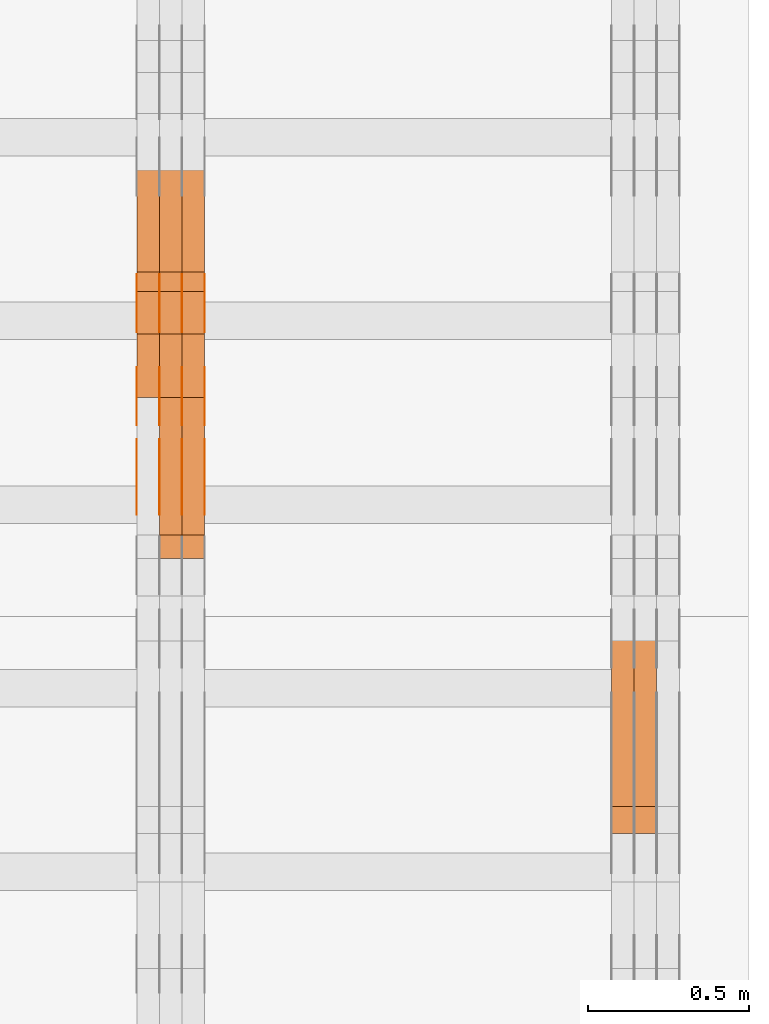
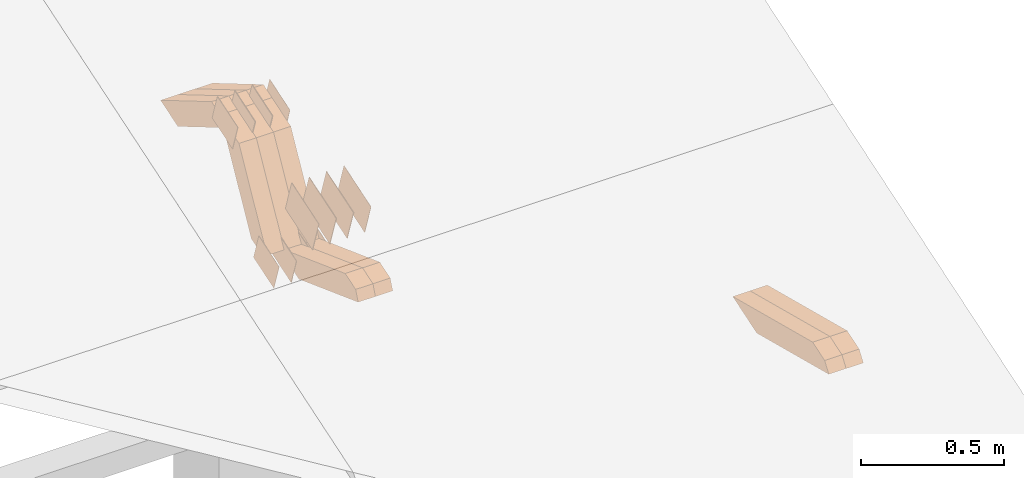
# One storey, part 316 of 385: 28 proxies.
"""IFC2X3 building model written with IfcOpenShell, lengths in millimetres."""

from ifc_helpers import new_model, entity, si_unit, converted_unit, derived_unit, direction, frame, origin, place, context, subcontext, project, spatial, polyline, outline, extrude, source, transform, mapped, material, type_object, type_shapes, element, save


model = new_model("IFC2X3")

# Units and contexts
model_context = context("Model", 3, precision=0.01, world=origin(), true_north=direction((6.12303176911189e-17, 1.0)))
body_context = subcontext(model_context, "Body", "Model", "MODEL_VIEW")
ifc_project = project(units=[si_unit("LENGTHUNIT", "METRE", prefix="MILLI"), si_unit("AREAUNIT", "SQUARE_METRE"), si_unit("VOLUMEUNIT", "CUBIC_METRE"), converted_unit("PLANEANGLEUNIT", "DEGREE", entity("IfcRatioMeasure", 0.0174532925199433), si_unit("PLANEANGLEUNIT", "RADIAN"), dimensions=[0, 0, 0, 0, 0, 0, 0]), si_unit("MASSUNIT", "GRAM", prefix="KILO"), derived_unit("MASSDENSITYUNIT", [(si_unit("MASSUNIT", "GRAM", prefix="KILO"), 1), (si_unit("LENGTHUNIT", "METRE"), -3)]), si_unit("TIMEUNIT", "SECOND"), si_unit("FREQUENCYUNIT", "HERTZ"), si_unit("THERMODYNAMICTEMPERATUREUNIT", "DEGREE_CELSIUS"), derived_unit("THERMALTRANSMITTANCEUNIT", [(si_unit("MASSUNIT", "GRAM", prefix="KILO"), 1), (si_unit("THERMODYNAMICTEMPERATUREUNIT", "KELVIN"), -1), (si_unit("TIMEUNIT", "SECOND"), -3)]), derived_unit("VOLUMETRICFLOWRATEUNIT", [(si_unit("LENGTHUNIT", "METRE"), 3), (si_unit("TIMEUNIT", "SECOND"), -1)]), si_unit("ELECTRICCURRENTUNIT", "AMPERE"), si_unit("ELECTRICVOLTAGEUNIT", "VOLT"), si_unit("POWERUNIT", "WATT"), si_unit("FORCEUNIT", "NEWTON", prefix="KILO"), si_unit("ILLUMINANCEUNIT", "LUX"), si_unit("LUMINOUSFLUXUNIT", "LUMEN"), si_unit("LUMINOUSINTENSITYUNIT", "CANDELA"), derived_unit("USERDEFINED", [(si_unit("MASSUNIT", "GRAM", prefix="KILO"), -1), (si_unit("LENGTHUNIT", "METRE"), -2), (si_unit("TIMEUNIT", "SECOND"), 3), (si_unit("LUMINOUSFLUXUNIT", "LUMEN"), 1)]), derived_unit("LINEARVELOCITYUNIT", [(si_unit("LENGTHUNIT", "METRE"), 1), (si_unit("TIMEUNIT", "SECOND"), -1)]), si_unit("PRESSUREUNIT", "PASCAL"), derived_unit("USERDEFINED", [(si_unit("LENGTHUNIT", "METRE"), -2), (si_unit("MASSUNIT", "GRAM", prefix="KILO"), 1), (si_unit("TIMEUNIT", "SECOND"), -2)])], contexts=[model_context])

# Site, building, storey
site_placement = place(None, origin())
site = spatial("IfcSite", under=ifc_project, at=site_placement, CompositionType="ELEMENT")
building_placement = place(site_placement, origin())
building = spatial("IfcBuilding", under=site, at=building_placement, CompositionType="ELEMENT")
storey_placement = place(building_placement, origin())
storey = spatial("IfcBuildingStorey", under=building, at=storey_placement, Name="Default", CompositionType="ELEMENT", Elevation=0.0)

# Proxies
ifc_material_1 = material(Name="IfcSurfaceStyle #598534")
building_element_proxy_type_1 = type_object("IfcBuildingElementProxyType", Name="T2-W11 598532", PredefinedType="NOTDEFINED", material=ifc_material_1)
shared_shape_1 = source(origin(), body_context, "Body", "SweptSolid", [
    extrude(outline(polyline([(-261.366417792209, -47.5000378467523), (260.949520182121, -47.5000378467523), (242.928845159301, -7.41559889341215e-06), (168.237407166939, 47.5000415545517), (-410.749354716152, 47.5000415545517), (-261.366417792209, -47.5000378467523)])), frame((260.949520182121, 47.5000415545517, 0.0), z_axis=(0.0, 0.0, 1.0), x_axis=(-1.0, 0.0, 0.0)), (0.0, 0.0, 1.0), 70.0),
])
type_shapes(building_element_proxy_type_1, [shared_shape_1])
proxy_1_placement = place(building_placement, frame((49790.0, 8017.44318793234, 2097.03832883996), z_axis=(-1.0, 0.0, 0.0), x_axis=(0.0, 0.968347201599873, -0.249607085543851)))
element("IfcBuildingElementProxy", 1, at=proxy_1_placement, inside=storey, type_object=building_element_proxy_type_1, material=ifc_material_1, Name="T2-W11", context=body_context, shape_type="MappedRepresentation", body=[
    mapped(shared_shape_1, transform((0.0, 0.0, 0.0), scale=1.0)),
])
ifc_material_2 = material(Name="IfcSurfaceStyle #598468")
building_element_proxy_type_2 = type_object("IfcBuildingElementProxyType", Name="T2-W11 598466", PredefinedType="NOTDEFINED", material=ifc_material_2)
shared_shape_2 = source(origin(), body_context, "Body", "SweptSolid", [
    extrude(outline(polyline([(-261.366417792209, -47.5000378467523), (260.949520182121, -47.5000378467523), (242.928845159301, -7.41559889341215e-06), (168.237407166939, 47.5000415545517), (-410.749354716152, 47.5000415545517), (-261.366417792209, -47.5000378467523)])), frame((260.949520182121, 47.5000415545517, 0.0), z_axis=(0.0, 0.0, 1.0), x_axis=(-1.0, 0.0, 0.0)), (0.0, 0.0, 1.0), 70.0),
])
type_shapes(building_element_proxy_type_2, [shared_shape_2])
proxy_2_placement = place(building_placement, frame((49720.0, 8017.44318793234, 2097.03832883996), z_axis=(-1.0, 0.0, 0.0), x_axis=(0.0, 0.968347201599873, -0.249607085543851)))
element("IfcBuildingElementProxy", 2, at=proxy_2_placement, inside=storey, type_object=building_element_proxy_type_2, material=ifc_material_2, Name="T2-W11", context=body_context, shape_type="MappedRepresentation", body=[
    mapped(shared_shape_2, transform((0.0, 0.0, 0.0), scale=1.0)),
])
ifc_material_3 = material(Name="IfcSurfaceStyle #590286")
building_element_proxy_type_3 = type_object("IfcBuildingElementProxyType", PredefinedType="NOTDEFINED", material=ifc_material_3)
shared_shape_3 = source(origin(), body_context, "Body", "SweptSolid", [
    extrude(outline(polyline([(-99.999644645517, -72.0000317581407), (100.000028485991, -72.0000317581407), (99.999644645517, 72.0000317581407), (-100.000028485991, 72.0000317581407), (-99.999644645517, -72.0000317581407)])), frame((100.000028485991, 72.0000317581407, 0.0), z_axis=(0.0, 0.0, 1.0), x_axis=(-1.0, 0.0, 0.0)), (0.0, 0.0, 1.0), 1.3),
])
type_shapes(building_element_proxy_type_3, [shared_shape_3])
proxy_3_placement = place(building_placement, frame((48386.3, 9012.6304394324, 2546.30522609783), z_axis=(-1.0, 0.0, 0.0), x_axis=(0.0, 0.951056516295154, 0.309016994374948)))
element("IfcBuildingElementProxy", 3, at=proxy_3_placement, inside=storey, type_object=building_element_proxy_type_3, material=ifc_material_3, context=body_context, shape_type="MappedRepresentation", body=[
    mapped(shared_shape_3, transform((0.0, 0.0, 0.0), scale=1.0)),
])
ifc_material_4 = material(Name="IfcSurfaceStyle #590229")
building_element_proxy_type_4 = type_object("IfcBuildingElementProxyType", PredefinedType="NOTDEFINED", material=ifc_material_4)
shared_shape_4 = source(origin(), body_context, "Body", "SweptSolid", [
    extrude(outline(polyline([(-99.999644645517, -72.0000317581407), (100.000028485991, -72.0000317581407), (99.999644645517, 72.0000317581407), (-100.000028485991, 72.0000317581407), (-99.999644645517, -72.0000317581407)])), frame((100.000028485991, 72.0000317581407, 0.0), z_axis=(0.0, 0.0, 1.0), x_axis=(-1.0, 0.0, 0.0)), (0.0, 0.0, 1.0), 1.3),
])
type_shapes(building_element_proxy_type_4, [shared_shape_4])
proxy_4_placement = place(building_placement, frame((48315.0, 9012.6304394324, 2546.30522609783), z_axis=(-1.0, 0.0, 0.0), x_axis=(0.0, 0.951056516295154, 0.309016994374948)))
element("IfcBuildingElementProxy", 4, at=proxy_4_placement, inside=storey, type_object=building_element_proxy_type_4, material=ifc_material_4, context=body_context, shape_type="MappedRepresentation", body=[
    mapped(shared_shape_4, transform((0.0, 0.0, 0.0), scale=1.0)),
])
ifc_material_5 = material(Name="IfcSurfaceStyle #590172")
building_element_proxy_type_5 = type_object("IfcBuildingElementProxyType", PredefinedType="NOTDEFINED", material=ifc_material_5)
shared_shape_5 = source(origin(), body_context, "Body", "SweptSolid", [
    extrude(outline(polyline([(-99.999644645517, -72.0000317581407), (100.000028485991, -72.0000317581407), (99.999644645517, 72.0000317581407), (-100.000028485991, 72.0000317581407), (-99.999644645517, -72.0000317581407)])), frame((100.000028485991, 72.0000317581407, 0.0), z_axis=(0.0, 0.0, 1.0), x_axis=(-1.0, 0.0, 0.0)), (0.0, 0.0, 1.0), 1.3),
])
type_shapes(building_element_proxy_type_5, [shared_shape_5])
proxy_5_placement = place(building_placement, frame((48316.3, 9012.6304394324, 2546.30522609783), z_axis=(-1.0, 0.0, 0.0), x_axis=(0.0, 0.951056516295154, 0.309016994374948)))
element("IfcBuildingElementProxy", 5, at=proxy_5_placement, inside=storey, type_object=building_element_proxy_type_5, material=ifc_material_5, context=body_context, shape_type="MappedRepresentation", body=[
    mapped(shared_shape_5, transform((0.0, 0.0, 0.0), scale=1.0)),
])
ifc_material_6 = material(Name="IfcSurfaceStyle #590115")
building_element_proxy_type_6 = type_object("IfcBuildingElementProxyType", PredefinedType="NOTDEFINED", material=ifc_material_6)
shared_shape_6 = source(origin(), body_context, "Body", "SweptSolid", [
    extrude(outline(polyline([(-99.999644645517, -72.0000317581407), (100.000028485991, -72.0000317581407), (99.999644645517, 72.0000317581407), (-100.000028485991, 72.0000317581407), (-99.999644645517, -72.0000317581407)])), frame((100.000028485991, 72.0000317581407, 0.0), z_axis=(0.0, 0.0, 1.0), x_axis=(-1.0, 0.0, 0.0)), (0.0, 0.0, 1.0), 1.29999999999998),
])
type_shapes(building_element_proxy_type_6, [shared_shape_6])
proxy_6_placement = place(building_placement, frame((48245.0, 9012.6304394324, 2546.30522609783), z_axis=(-1.0, 0.0, 0.0), x_axis=(0.0, 0.951056516295154, 0.309016994374948)))
element("IfcBuildingElementProxy", 6, at=proxy_6_placement, inside=storey, type_object=building_element_proxy_type_6, material=ifc_material_6, context=body_context, shape_type="MappedRepresentation", body=[
    mapped(shared_shape_6, transform((0.0, 0.0, 0.0), scale=1.0)),
])
ifc_material_7 = material(Name="IfcSurfaceStyle #590058")
building_element_proxy_type_7 = type_object("IfcBuildingElementProxyType", PredefinedType="NOTDEFINED", material=ifc_material_7)
shared_shape_7 = source(origin(), body_context, "Body", "SweptSolid", [
    extrude(outline(polyline([(-99.999644645517, -72.0000317581407), (100.000028485991, -72.0000317581407), (99.999644645517, 72.0000317581407), (-100.000028485991, 72.0000317581407), (-99.999644645517, -72.0000317581407)])), frame((100.000028485991, 72.0000317581407, 0.0), z_axis=(0.0, 0.0, 1.0), x_axis=(-1.0, 0.0, 0.0)), (0.0, 0.0, 1.0), 1.29999999999998),
])
type_shapes(building_element_proxy_type_7, [shared_shape_7])
proxy_7_placement = place(building_placement, frame((48246.3, 9012.6304394324, 2546.30522609783), z_axis=(-1.0, 0.0, 0.0), x_axis=(0.0, 0.951056516295154, 0.309016994374948)))
element("IfcBuildingElementProxy", 7, at=proxy_7_placement, inside=storey, type_object=building_element_proxy_type_7, material=ifc_material_7, context=body_context, shape_type="MappedRepresentation", body=[
    mapped(shared_shape_7, transform((0.0, 0.0, 0.0), scale=1.0)),
])
ifc_material_8 = material(Name="IfcSurfaceStyle #590001")
building_element_proxy_type_8 = type_object("IfcBuildingElementProxyType", PredefinedType="NOTDEFINED", material=ifc_material_8)
shared_shape_8 = source(origin(), body_context, "Body", "SweptSolid", [
    extrude(outline(polyline([(-99.999644645517, -72.0000317581407), (100.000028485991, -72.0000317581407), (99.999644645517, 72.0000317581407), (-100.000028485991, 72.0000317581407), (-99.999644645517, -72.0000317581407)])), frame((100.000028485991, 72.0000317581407, 0.0), z_axis=(0.0, 0.0, 1.0), x_axis=(-1.0, 0.0, 0.0)), (0.0, 0.0, 1.0), 1.29999999999999),
])
type_shapes(building_element_proxy_type_8, [shared_shape_8])
proxy_8_placement = place(building_placement, frame((48175.0, 9012.6304394324, 2546.30522609783), z_axis=(-1.0, 0.0, 0.0), x_axis=(0.0, 0.951056516295154, 0.309016994374948)))
element("IfcBuildingElementProxy", 8, at=proxy_8_placement, inside=storey, type_object=building_element_proxy_type_8, material=ifc_material_8, context=body_context, shape_type="MappedRepresentation", body=[
    mapped(shared_shape_8, transform((0.0, 0.0, 0.0), scale=1.0)),
])
ifc_material_9 = material(Name="IfcSurfaceStyle #589944")
building_element_proxy_type_9 = type_object("IfcBuildingElementProxyType", PredefinedType="NOTDEFINED", material=ifc_material_9)
shared_shape_9 = source(origin(), body_context, "Body", "SweptSolid", [
    extrude(outline(polyline([(-74.9998754286207, -60.0000016373506), (74.9998605591063, -60.0000016373506), (74.9998754286244, 60.0000016373506), (-74.9998605591099, 60.0000016373506), (-74.9998754286207, -60.0000016373506)])), frame((74.9998754286244, 60.0000016373506, 0.0), z_axis=(0.0, 0.0, 1.0), x_axis=(-1.0, 0.0, 0.0)), (0.0, 0.0, 1.0), 1.3),
])
type_shapes(building_element_proxy_type_9, [shared_shape_9])
proxy_9_placement = place(building_placement, frame((48386.3, 9580.89841427132, 2615.81135078741), z_axis=(-1.0, 0.0, 0.0), x_axis=(0.0, 0.951056516295154, 0.309016994374948)))
element("IfcBuildingElementProxy", 9, at=proxy_9_placement, inside=storey, type_object=building_element_proxy_type_9, material=ifc_material_9, context=body_context, shape_type="MappedRepresentation", body=[
    mapped(shared_shape_9, transform((0.0, 0.0, 0.0), scale=1.0)),
])
ifc_material_10 = material(Name="IfcSurfaceStyle #589887")
building_element_proxy_type_10 = type_object("IfcBuildingElementProxyType", PredefinedType="NOTDEFINED", material=ifc_material_10)
shared_shape_10 = source(origin(), body_context, "Body", "SweptSolid", [
    extrude(outline(polyline([(-74.9998754286207, -60.0000016373506), (74.9998605591063, -60.0000016373506), (74.9998754286244, 60.0000016373506), (-74.9998605591099, 60.0000016373506), (-74.9998754286207, -60.0000016373506)])), frame((74.9998754286244, 60.0000016373506, 0.0), z_axis=(0.0, 0.0, 1.0), x_axis=(-1.0, 0.0, 0.0)), (0.0, 0.0, 1.0), 1.3),
])
type_shapes(building_element_proxy_type_10, [shared_shape_10])
proxy_10_placement = place(building_placement, frame((48315.0, 9580.89841427132, 2615.81135078741), z_axis=(-1.0, 0.0, 0.0), x_axis=(0.0, 0.951056516295154, 0.309016994374948)))
element("IfcBuildingElementProxy", 10, at=proxy_10_placement, inside=storey, type_object=building_element_proxy_type_10, material=ifc_material_10, context=body_context, shape_type="MappedRepresentation", body=[
    mapped(shared_shape_10, transform((0.0, 0.0, 0.0), scale=1.0)),
])
ifc_material_11 = material(Name="IfcSurfaceStyle #589830")
building_element_proxy_type_11 = type_object("IfcBuildingElementProxyType", PredefinedType="NOTDEFINED", material=ifc_material_11)
shared_shape_11 = source(origin(), body_context, "Body", "SweptSolid", [
    extrude(outline(polyline([(-74.9998754286207, -60.0000016373506), (74.9998605591063, -60.0000016373506), (74.9998754286244, 60.0000016373506), (-74.9998605591099, 60.0000016373506), (-74.9998754286207, -60.0000016373506)])), frame((74.9998754286244, 60.0000016373506, 0.0), z_axis=(0.0, 0.0, 1.0), x_axis=(-1.0, 0.0, 0.0)), (0.0, 0.0, 1.0), 1.3),
])
type_shapes(building_element_proxy_type_11, [shared_shape_11])
proxy_11_placement = place(building_placement, frame((48316.3, 9580.89841427132, 2615.81135078741), z_axis=(-1.0, 0.0, 0.0), x_axis=(0.0, 0.951056516295154, 0.309016994374948)))
element("IfcBuildingElementProxy", 11, at=proxy_11_placement, inside=storey, type_object=building_element_proxy_type_11, material=ifc_material_11, context=body_context, shape_type="MappedRepresentation", body=[
    mapped(shared_shape_11, transform((0.0, 0.0, 0.0), scale=1.0)),
])
ifc_material_12 = material(Name="IfcSurfaceStyle #589773")
building_element_proxy_type_12 = type_object("IfcBuildingElementProxyType", PredefinedType="NOTDEFINED", material=ifc_material_12)
shared_shape_12 = source(origin(), body_context, "Body", "SweptSolid", [
    extrude(outline(polyline([(-74.9998754286207, -60.0000016373506), (74.9998605591063, -60.0000016373506), (74.9998754286244, 60.0000016373506), (-74.9998605591099, 60.0000016373506), (-74.9998754286207, -60.0000016373506)])), frame((74.9998754286244, 60.0000016373506, 0.0), z_axis=(0.0, 0.0, 1.0), x_axis=(-1.0, 0.0, 0.0)), (0.0, 0.0, 1.0), 1.29999999999999),
])
type_shapes(building_element_proxy_type_12, [shared_shape_12])
proxy_12_placement = place(building_placement, frame((48245.0, 9580.89841427132, 2615.81135078741), z_axis=(-1.0, 0.0, 0.0), x_axis=(0.0, 0.951056516295154, 0.309016994374948)))
element("IfcBuildingElementProxy", 12, at=proxy_12_placement, inside=storey, type_object=building_element_proxy_type_12, material=ifc_material_12, context=body_context, shape_type="MappedRepresentation", body=[
    mapped(shared_shape_12, transform((0.0, 0.0, 0.0), scale=1.0)),
])
ifc_material_13 = material(Name="IfcSurfaceStyle #589716")
building_element_proxy_type_13 = type_object("IfcBuildingElementProxyType", PredefinedType="NOTDEFINED", material=ifc_material_13)
shared_shape_13 = source(origin(), body_context, "Body", "SweptSolid", [
    extrude(outline(polyline([(-74.9998754286207, -60.0000016373506), (74.9998605591063, -60.0000016373506), (74.9998754286244, 60.0000016373506), (-74.9998605591099, 60.0000016373506), (-74.9998754286207, -60.0000016373506)])), frame((74.9998754286244, 60.0000016373506, 0.0), z_axis=(0.0, 0.0, 1.0), x_axis=(-1.0, 0.0, 0.0)), (0.0, 0.0, 1.0), 1.29999999999999),
])
type_shapes(building_element_proxy_type_13, [shared_shape_13])
proxy_13_placement = place(building_placement, frame((48246.3, 9580.89841427132, 2615.81135078741), z_axis=(-1.0, 0.0, 0.0), x_axis=(0.0, 0.951056516295154, 0.309016994374948)))
element("IfcBuildingElementProxy", 13, at=proxy_13_placement, inside=storey, type_object=building_element_proxy_type_13, material=ifc_material_13, context=body_context, shape_type="MappedRepresentation", body=[
    mapped(shared_shape_13, transform((0.0, 0.0, 0.0), scale=1.0)),
])
ifc_material_14 = material(Name="IfcSurfaceStyle #589659")
building_element_proxy_type_14 = type_object("IfcBuildingElementProxyType", PredefinedType="NOTDEFINED", material=ifc_material_14)
shared_shape_14 = source(origin(), body_context, "Body", "SweptSolid", [
    extrude(outline(polyline([(-74.9998754286207, -60.0000016373506), (74.9998605591063, -60.0000016373506), (74.9998754286244, 60.0000016373506), (-74.9998605591099, 60.0000016373506), (-74.9998754286207, -60.0000016373506)])), frame((74.9998754286244, 60.0000016373506, 0.0), z_axis=(0.0, 0.0, 1.0), x_axis=(-1.0, 0.0, 0.0)), (0.0, 0.0, 1.0), 1.29999999999999),
])
type_shapes(building_element_proxy_type_14, [shared_shape_14])
proxy_14_placement = place(building_placement, frame((48175.0, 9580.89841427132, 2615.81135078741), z_axis=(-1.0, 0.0, 0.0), x_axis=(0.0, 0.951056516295154, 0.309016994374948)))
element("IfcBuildingElementProxy", 14, at=proxy_14_placement, inside=storey, type_object=building_element_proxy_type_14, material=ifc_material_14, context=body_context, shape_type="MappedRepresentation", body=[
    mapped(shared_shape_14, transform((0.0, 0.0, 0.0), scale=1.0)),
])
ifc_material_15 = material(Name="IfcSurfaceStyle #588918")
building_element_proxy_type_15 = type_object("IfcBuildingElementProxyType", PredefinedType="NOTDEFINED", material=ifc_material_15)
shared_shape_15 = source(origin(), body_context, "Body", "SweptSolid", [
    extrude(outline(polyline([(-75.0008041947458, -59.9996998629349), (75.0007893252423, -59.9996998629349), (75.0008041947458, 59.9996998629349), (-75.0007893252423, 59.9996998629349), (-75.0008041947458, -59.9996998629349)])), frame((75.0008041947458, 60.0002282421692, 0.0), z_axis=(0.0, 0.0, 1.0), x_axis=(-1.0, 0.0, 0.0)), (0.0, 0.0, 1.0), 1.3),
])
type_shapes(building_element_proxy_type_15, [shared_shape_15])
proxy_15_placement = place(building_placement, frame((48386.3, 9291.04882812501, 2194.94482421875), z_axis=(-1.0, 0.0, 0.0), x_axis=(0.0, 0.951056516295124, 0.309016994375039)))
element("IfcBuildingElementProxy", 15, at=proxy_15_placement, inside=storey, type_object=building_element_proxy_type_15, material=ifc_material_15, context=body_context, shape_type="MappedRepresentation", body=[
    mapped(shared_shape_15, transform((0.0, 0.0, 0.0), scale=1.0)),
])
ifc_material_16 = material(Name="IfcSurfaceStyle #588861")
building_element_proxy_type_16 = type_object("IfcBuildingElementProxyType", PredefinedType="NOTDEFINED", material=ifc_material_16)
shared_shape_16 = source(origin(), body_context, "Body", "SweptSolid", [
    extrude(outline(polyline([(-75.0008041947458, -59.9996998629349), (75.0007893252423, -59.9996998629349), (75.0008041947458, 59.9996998629349), (-75.0007893252423, 59.9996998629349), (-75.0008041947458, -59.9996998629349)])), frame((75.0008041947458, 60.0002282421692, 0.0), z_axis=(0.0, 0.0, 1.0), x_axis=(-1.0, 0.0, 0.0)), (0.0, 0.0, 1.0), 1.3),
])
type_shapes(building_element_proxy_type_16, [shared_shape_16])
proxy_16_placement = place(building_placement, frame((48315.0, 9291.04882812501, 2194.94482421875), z_axis=(-1.0, 0.0, 0.0), x_axis=(0.0, 0.951056516295124, 0.309016994375039)))
element("IfcBuildingElementProxy", 16, at=proxy_16_placement, inside=storey, type_object=building_element_proxy_type_16, material=ifc_material_16, context=body_context, shape_type="MappedRepresentation", body=[
    mapped(shared_shape_16, transform((0.0, 0.0, 0.0), scale=1.0)),
])
ifc_material_17 = material(Name="IfcSurfaceStyle #588804")
building_element_proxy_type_17 = type_object("IfcBuildingElementProxyType", PredefinedType="NOTDEFINED", material=ifc_material_17)
shared_shape_17 = source(origin(), body_context, "Body", "SweptSolid", [
    extrude(outline(polyline([(-75.0008041947458, -59.9996998629349), (75.0007893252423, -59.9996998629349), (75.0008041947458, 59.9996998629349), (-75.0007893252423, 59.9996998629349), (-75.0008041947458, -59.9996998629349)])), frame((75.0008041947458, 60.0002282421692, 0.0), z_axis=(0.0, 0.0, 1.0), x_axis=(-1.0, 0.0, 0.0)), (0.0, 0.0, 1.0), 1.3),
])
type_shapes(building_element_proxy_type_17, [shared_shape_17])
proxy_17_placement = place(building_placement, frame((48316.3, 9291.04882812501, 2194.94482421875), z_axis=(-1.0, 0.0, 0.0), x_axis=(0.0, 0.951056516295124, 0.309016994375039)))
element("IfcBuildingElementProxy", 17, at=proxy_17_placement, inside=storey, type_object=building_element_proxy_type_17, material=ifc_material_17, context=body_context, shape_type="MappedRepresentation", body=[
    mapped(shared_shape_17, transform((0.0, 0.0, 0.0), scale=1.0)),
])
ifc_material_18 = material(Name="IfcSurfaceStyle #588747")
building_element_proxy_type_18 = type_object("IfcBuildingElementProxyType", PredefinedType="NOTDEFINED", material=ifc_material_18)
shared_shape_18 = source(origin(), body_context, "Body", "SweptSolid", [
    extrude(outline(polyline([(-75.0008041947458, -59.9996998629349), (75.0007893252423, -59.9996998629349), (75.0008041947458, 59.9996998629349), (-75.0007893252423, 59.9996998629349), (-75.0008041947458, -59.9996998629349)])), frame((75.0008041947458, 60.0002282421692, 0.0), z_axis=(0.0, 0.0, 1.0), x_axis=(-1.0, 0.0, 0.0)), (0.0, 0.0, 1.0), 1.29999999999999),
])
type_shapes(building_element_proxy_type_18, [shared_shape_18])
proxy_18_placement = place(building_placement, frame((48245.0, 9291.04882812501, 2194.94482421875), z_axis=(-1.0, 0.0, 0.0), x_axis=(0.0, 0.951056516295124, 0.309016994375039)))
element("IfcBuildingElementProxy", 18, at=proxy_18_placement, inside=storey, type_object=building_element_proxy_type_18, material=ifc_material_18, context=body_context, shape_type="MappedRepresentation", body=[
    mapped(shared_shape_18, transform((0.0, 0.0, 0.0), scale=1.0)),
])
ifc_material_19 = material(Name="IfcSurfaceStyle #588690")
building_element_proxy_type_19 = type_object("IfcBuildingElementProxyType", PredefinedType="NOTDEFINED", material=ifc_material_19)
shared_shape_19 = source(origin(), body_context, "Body", "SweptSolid", [
    extrude(outline(polyline([(-75.0008041947458, -59.9996998629349), (75.0007893252423, -59.9996998629349), (75.0008041947458, 59.9996998629349), (-75.0007893252423, 59.9996998629349), (-75.0008041947458, -59.9996998629349)])), frame((75.0008041947458, 60.0002282421692, 0.0), z_axis=(0.0, 0.0, 1.0), x_axis=(-1.0, 0.0, 0.0)), (0.0, 0.0, 1.0), 1.29999999999999),
])
type_shapes(building_element_proxy_type_19, [shared_shape_19])
proxy_19_placement = place(building_placement, frame((48246.3, 9291.04882812501, 2194.94482421875), z_axis=(-1.0, 0.0, 0.0), x_axis=(0.0, 0.951056516295124, 0.309016994375039)))
element("IfcBuildingElementProxy", 19, at=proxy_19_placement, inside=storey, type_object=building_element_proxy_type_19, material=ifc_material_19, context=body_context, shape_type="MappedRepresentation", body=[
    mapped(shared_shape_19, transform((0.0, 0.0, 0.0), scale=1.0)),
])
ifc_material_20 = material(Name="IfcSurfaceStyle #588633")
building_element_proxy_type_20 = type_object("IfcBuildingElementProxyType", PredefinedType="NOTDEFINED", material=ifc_material_20)
shared_shape_20 = source(origin(), body_context, "Body", "SweptSolid", [
    extrude(outline(polyline([(-75.0008041947458, -59.9996998629349), (75.0007893252423, -59.9996998629349), (75.0008041947458, 59.9996998629349), (-75.0007893252423, 59.9996998629349), (-75.0008041947458, -59.9996998629349)])), frame((75.0008041947458, 60.0002282421692, 0.0), z_axis=(0.0, 0.0, 1.0), x_axis=(-1.0, 0.0, 0.0)), (0.0, 0.0, 1.0), 1.29999999999999),
])
type_shapes(building_element_proxy_type_20, [shared_shape_20])
proxy_20_placement = place(building_placement, frame((48175.0, 9291.04882812501, 2194.94482421875), z_axis=(-1.0, 0.0, 0.0), x_axis=(0.0, 0.951056516295124, 0.309016994375039)))
element("IfcBuildingElementProxy", 20, at=proxy_20_placement, inside=storey, type_object=building_element_proxy_type_20, material=ifc_material_20, context=body_context, shape_type="MappedRepresentation", body=[
    mapped(shared_shape_20, transform((0.0, 0.0, 0.0), scale=1.0)),
])
ifc_material_21 = material(Name="IfcSurfaceStyle #565752")
building_element_proxy_type_21 = type_object("IfcBuildingElementProxyType", Name="T1-W43 565750", PredefinedType="NOTDEFINED", material=ifc_material_21)
shared_shape_21 = source(origin(), body_context, "Body", "SweptSolid", [
    extrude(outline(polyline([(-198.159905426436, -47.4999961988362), (173.155878681738, -47.4999961988362), (174.585865234707, -0.00038778214839239), (132.582704932703, 47.5001900899104), (-282.164543422712, 47.5001900899104), (-198.159905426436, -47.4999961988362)])), frame((174.585865234707, 47.5001900899104, 0.0), z_axis=(0.0, 0.0, 1.0), x_axis=(-1.0, 0.0, 0.0)), (0.0, 0.0, 1.0), 70.0),
])
type_shapes(building_element_proxy_type_21, [shared_shape_21])
proxy_21_placement = place(building_placement, frame((48385.0, 9730.71877771153, 2634.4881681647), z_axis=(-1.0, 0.0, 0.0), x_axis=(0.0, 0.861495156633645, -0.507765787639115)))
element("IfcBuildingElementProxy", 21, at=proxy_21_placement, inside=storey, type_object=building_element_proxy_type_21, material=ifc_material_21, Name="T1-W43", context=body_context, shape_type="MappedRepresentation", body=[
    mapped(shared_shape_21, transform((0.0, 0.0, 0.0), scale=1.0)),
])
ifc_material_22 = material(Name="IfcSurfaceStyle #565686")
building_element_proxy_type_22 = type_object("IfcBuildingElementProxyType", Name="T1-W43 565684", PredefinedType="NOTDEFINED", material=ifc_material_22)
shared_shape_22 = source(origin(), body_context, "Body", "SweptSolid", [
    extrude(outline(polyline([(-198.159905426436, -47.4999961988362), (173.155878681738, -47.4999961988362), (174.585865234707, -0.00038778214839239), (132.582704932703, 47.5001900899104), (-282.164543422712, 47.5001900899104), (-198.159905426436, -47.4999961988362)])), frame((174.585865234707, 47.5001900899104, 0.0), z_axis=(0.0, 0.0, 1.0), x_axis=(-1.0, 0.0, 0.0)), (0.0, 0.0, 1.0), 70.0),
])
type_shapes(building_element_proxy_type_22, [shared_shape_22])
proxy_22_placement = place(building_placement, frame((48315.0, 9730.71877771153, 2634.4881681647), z_axis=(-1.0, 0.0, 0.0), x_axis=(0.0, 0.861495156633645, -0.507765787639115)))
element("IfcBuildingElementProxy", 22, at=proxy_22_placement, inside=storey, type_object=building_element_proxy_type_22, material=ifc_material_22, Name="T1-W43", context=body_context, shape_type="MappedRepresentation", body=[
    mapped(shared_shape_22, transform((0.0, 0.0, 0.0), scale=1.0)),
])
ifc_material_23 = material(Name="IfcSurfaceStyle #565620")
building_element_proxy_type_23 = type_object("IfcBuildingElementProxyType", Name="T1-W43 565618", PredefinedType="NOTDEFINED", material=ifc_material_23)
shared_shape_23 = source(origin(), body_context, "Body", "SweptSolid", [
    extrude(outline(polyline([(-198.159905426436, -47.4999961988362), (173.155878681738, -47.4999961988362), (174.585865234707, -0.00038778214839239), (132.582704932703, 47.5001900899104), (-282.164543422712, 47.5001900899104), (-198.159905426436, -47.4999961988362)])), frame((174.585865234707, 47.5001900899104, 0.0), z_axis=(0.0, 0.0, 1.0), x_axis=(-1.0, 0.0, 0.0)), (0.0, 0.0, 1.0), 70.0),
])
type_shapes(building_element_proxy_type_23, [shared_shape_23])
proxy_23_placement = place(building_placement, frame((48245.0, 9730.71877771153, 2634.4881681647), z_axis=(-1.0, 0.0, 0.0), x_axis=(0.0, 0.861495156633645, -0.507765787639115)))
element("IfcBuildingElementProxy", 23, at=proxy_23_placement, inside=storey, type_object=building_element_proxy_type_23, material=ifc_material_23, Name="T1-W43", context=body_context, shape_type="MappedRepresentation", body=[
    mapped(shared_shape_23, transform((0.0, 0.0, 0.0), scale=1.0)),
])
ifc_material_24 = material(Name="IfcSurfaceStyle #565356")
building_element_proxy_type_24 = type_object("IfcBuildingElementProxyType", Name="T1-W33 565354", PredefinedType="NOTDEFINED", material=ifc_material_24)
shared_shape_24 = source(origin(), body_context, "Body", "SweptSolid", [
    extrude(outline(polyline([(-314.173070820175, -47.4997758466969), (139.635944117881, -47.4997758466969), (190.204920608233, 0.000348187720347082), (197.369205310989, 47.5001702328475), (-213.036999216928, 47.4990332728259), (-314.173070820175, -47.4997758466969)])), frame((197.369205310989, 47.5001702328475, 0.0), z_axis=(0.0, 0.0, 1.0), x_axis=(-1.0, 0.0, 0.0)), (0.0, 0.0, 1.0), 70.0),
])
type_shapes(building_element_proxy_type_24, [shared_shape_24])
proxy_24_placement = place(building_placement, frame((48385.0, 9376.96875, 2191.01977539063), z_axis=(-1.0, 0.0, 0.0), x_axis=(0.0, 0.481632628948835, 0.876373214293907)))
element("IfcBuildingElementProxy", 24, at=proxy_24_placement, inside=storey, type_object=building_element_proxy_type_24, material=ifc_material_24, Name="T1-W33", context=body_context, shape_type="MappedRepresentation", body=[
    mapped(shared_shape_24, transform((0.0, 0.0, 0.0), scale=1.0)),
])
ifc_material_25 = material(Name="IfcSurfaceStyle #565290")
building_element_proxy_type_25 = type_object("IfcBuildingElementProxyType", Name="T1-W33 565288", PredefinedType="NOTDEFINED", material=ifc_material_25)
shared_shape_25 = source(origin(), body_context, "Body", "SweptSolid", [
    extrude(outline(polyline([(-314.173070820175, -47.4997758466969), (139.635944117881, -47.4997758466969), (190.204920608233, 0.000348187720347082), (197.369205310989, 47.5001702328475), (-213.036999216928, 47.4990332728259), (-314.173070820175, -47.4997758466969)])), frame((197.369205310989, 47.5001702328475, 0.0), z_axis=(0.0, 0.0, 1.0), x_axis=(-1.0, 0.0, 0.0)), (0.0, 0.0, 1.0), 70.0),
])
type_shapes(building_element_proxy_type_25, [shared_shape_25])
proxy_25_placement = place(building_placement, frame((48315.0, 9376.96875, 2191.01977539063), z_axis=(-1.0, 0.0, 0.0), x_axis=(0.0, 0.481632628948835, 0.876373214293907)))
element("IfcBuildingElementProxy", 25, at=proxy_25_placement, inside=storey, type_object=building_element_proxy_type_25, material=ifc_material_25, Name="T1-W33", context=body_context, shape_type="MappedRepresentation", body=[
    mapped(shared_shape_25, transform((0.0, 0.0, 0.0), scale=1.0)),
])
ifc_material_26 = material(Name="IfcSurfaceStyle #565224")
building_element_proxy_type_26 = type_object("IfcBuildingElementProxyType", Name="T1-W33 565222", PredefinedType="NOTDEFINED", material=ifc_material_26)
shared_shape_26 = source(origin(), body_context, "Body", "SweptSolid", [
    extrude(outline(polyline([(-314.173070820175, -47.4997758466969), (139.635944117881, -47.4997758466969), (190.204920608233, 0.000348187720347082), (197.369205310989, 47.5001702328475), (-213.036999216928, 47.4990332728259), (-314.173070820175, -47.4997758466969)])), frame((197.369205310989, 47.5001702328475, 0.0), z_axis=(0.0, 0.0, 1.0), x_axis=(-1.0, 0.0, 0.0)), (0.0, 0.0, 1.0), 70.0),
])
type_shapes(building_element_proxy_type_26, [shared_shape_26])
proxy_26_placement = place(building_placement, frame((48245.0, 9376.96875, 2191.01977539063), z_axis=(-1.0, 0.0, 0.0), x_axis=(0.0, 0.481632628948835, 0.876373214293907)))
element("IfcBuildingElementProxy", 26, at=proxy_26_placement, inside=storey, type_object=building_element_proxy_type_26, material=ifc_material_26, Name="T1-W33", context=body_context, shape_type="MappedRepresentation", body=[
    mapped(shared_shape_26, transform((0.0, 0.0, 0.0), scale=1.0)),
])
ifc_material_27 = material(Name="IfcSurfaceStyle #564960")
building_element_proxy_type_27 = type_object("IfcBuildingElementProxyType", Name="T1-W25 564958", PredefinedType="NOTDEFINED", material=ifc_material_27)
shared_shape_27 = source(origin(), body_context, "Body", "SweptSolid", [
    extrude(outline(polyline([(-229.232772462784, -47.5001671709529), (214.075939394384, -47.5001671709529), (212.688957821661, -0.000141058964427199), (152.358910178478, 47.5002377004352), (-349.891034931738, 47.5002377004352), (-229.232772462784, -47.5001671709529)])), frame((214.075939394384, 47.5002377004352, 0.0), z_axis=(0.0, 0.0, 1.0), x_axis=(-1.0, 0.0, 0.0)), (0.0, 0.0, 1.0), 70.0),
])
type_shapes(building_element_proxy_type_27, [shared_shape_27])
proxy_27_placement = place(building_placement, frame((48385.0, 8892.81895960243, 2369.29665807578), z_axis=(-1.0, 0.0, 0.0), x_axis=(0.0, 0.938402514401222, -0.345544094097213)))
element("IfcBuildingElementProxy", 27, at=proxy_27_placement, inside=storey, type_object=building_element_proxy_type_27, material=ifc_material_27, Name="T1-W25", context=body_context, shape_type="MappedRepresentation", body=[
    mapped(shared_shape_27, transform((0.0, 0.0, 0.0), scale=1.0)),
])
ifc_material_28 = material(Name="IfcSurfaceStyle #564894")
building_element_proxy_type_28 = type_object("IfcBuildingElementProxyType", Name="T1-W25 564892", PredefinedType="NOTDEFINED", material=ifc_material_28)
shared_shape_28 = source(origin(), body_context, "Body", "SweptSolid", [
    extrude(outline(polyline([(-229.232772462784, -47.5001671709529), (214.075939394384, -47.5001671709529), (212.688957821661, -0.000141058964427199), (152.358910178478, 47.5002377004352), (-349.891034931738, 47.5002377004352), (-229.232772462784, -47.5001671709529)])), frame((214.075939394384, 47.5002377004352, 0.0), z_axis=(0.0, 0.0, 1.0), x_axis=(-1.0, 0.0, 0.0)), (0.0, 0.0, 1.0), 70.0),
])
type_shapes(building_element_proxy_type_28, [shared_shape_28])
proxy_28_placement = place(building_placement, frame((48315.0, 8892.81895960243, 2369.29665807578), z_axis=(-1.0, 0.0, 0.0), x_axis=(0.0, 0.938402514401222, -0.345544094097213)))
element("IfcBuildingElementProxy", 28, at=proxy_28_placement, inside=storey, type_object=building_element_proxy_type_28, material=ifc_material_28, Name="T1-W25", context=body_context, shape_type="MappedRepresentation", body=[
    mapped(shared_shape_28, transform((0.0, 0.0, 0.0), scale=1.0)),
])

save(model, "model.ifc")
